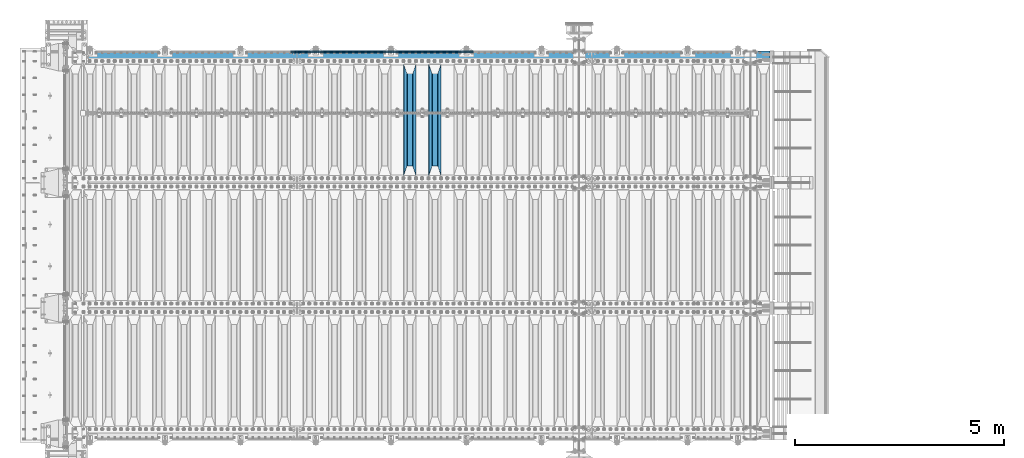
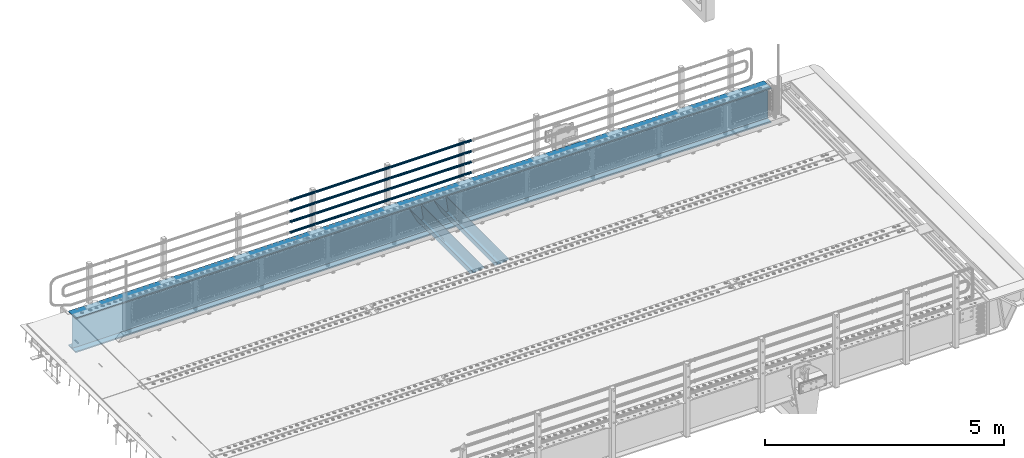
# One storey, part 125 of 247: 7 beams.
"""IFC2X3 building model written with IfcOpenShell, lengths in millimetres."""

from ifc_helpers import new_model, si_unit, frame, origin_with_axes, place, context, subcontext, project, spatial, faceted_brep, material, type_object, element, save


model = new_model("IFC2X3")

# Units and contexts
model_context = context("Model", 3, precision=1e-05, world=origin_with_axes())
body_context = subcontext(model_context, "Body", "Model", "MODEL_VIEW")
ifc_project = project(units=[si_unit("LENGTHUNIT", "METRE", prefix="MILLI"), si_unit("AREAUNIT", "SQUARE_METRE"), si_unit("VOLUMEUNIT", "CUBIC_METRE"), si_unit("MASSUNIT", "GRAM", prefix="KILO"), si_unit("TIMEUNIT", "SECOND"), si_unit("PLANEANGLEUNIT", "RADIAN"), si_unit("SOLIDANGLEUNIT", "STERADIAN"), si_unit("THERMODYNAMICTEMPERATUREUNIT", "DEGREE_CELSIUS"), si_unit("LUMINOUSINTENSITYUNIT", "LUMEN")], contexts=[model_context])

# Site, building, storey
site_placement = place(None, origin_with_axes())
site = spatial("IfcSite", under=ifc_project, at=site_placement, CompositionType="ELEMENT")
building_placement = place(site_placement, origin_with_axes())
building = spatial("IfcBuilding", under=site, at=building_placement, Name="Standard", CompositionType="ELEMENT")
storey_placement = place(building_placement, origin_with_axes())
storey = spatial("IfcBuildingStorey", under=building, at=storey_placement, Name="Undefined", CompositionType="ELEMENT", Elevation=0.0)

# Beams
ifc_material_1 = material(Name="STEEL/S355N")
beam_type_1 = type_object("IfcBeamType", PredefinedType="NOTDEFINED")
beam_1_placement = place(storey_placement, frame((8800.0, 6175.0, -115.0), z_axis=(0.0, 0.0, 1.0), x_axis=(0.0, 1.0, 0.0)))
element("IfcBeam", 1, at=beam_1_placement, inside=storey, type_object=beam_type_1, material=ifc_material_1, context=body_context, shape_type="Brep", body=[
    faceted_brep([(0.0, 150.0, 115.0), (0.0, 143.689999999999, 115.0), (2650.00000000297, 143.689999999999, 115.0), (2650.00000000297, 150.0, 115.0), (2650.00000000297, 142.059565218402, 110.0000000031), (2650.00000000297, 148.369565218403, 110.0000000031), (2441.90079219208, -80.1103600731112, -98.0992078077845), (2437.7588105432, -77.5672621345584, -102.241189456673), (2434.06523489746, -74.4080125315522, -105.934765102404), (2430.91086095089, -70.710272125576, -109.089139048974), (2428.37322971128, -66.5649389910068, -111.626770288588), (2426.51472138054, -62.0739139532889, -113.485278619323), (2425.38102192091, -57.3475956567672, -114.618978078955), (2424.99999999987, -52.5021667386536, -115.0), (2424.99999999987, 52.5021667386536, -115.0), (2425.38102192091, 57.3475956567672, -114.618978078955), (2426.51472138054, 62.0739139532889, -113.485278619323), (2428.37322971128, 66.5649389910068, -111.626770288588), (2430.91086095089, 70.710272125576, -109.089139048974), (2434.06523489746, 74.4080125315522, -105.934765102404), (2437.7588105432, 77.5672621345584, -102.241189456673), (2441.90079219208, 80.1103600731112, -98.0992078077846), (2446.38936140511, 81.9747917625791, -93.6106385947584), (2448.24948500409, 76.2713538057251, -91.7505149957729), (2444.62967112262, 74.76777986261, -95.3703288772456), (2441.28936334126, 72.7168944282894, -98.710636658607), (2438.31067330438, 70.1691124903846, -101.689326695487), (2435.76682334747, 67.1870637758839, -104.233176652398), (2433.72034654133, 63.8440531834895, -106.279653458539), (2432.22154950041, 60.222258798236, -107.778450499454), (2431.30727574265, 56.4107117849089, -108.692724257221), (2430.99999999987, 52.5031078186876, -109.0), (2430.99999999987, -52.5031078186876, -109.0), (2431.30727574265, -56.4107117849089, -108.692724257221), (2432.22154950041, -60.222258798236, -107.778450499454), (2433.72034654133, -63.8440531834895, -106.279653458539), (2435.76682334747, -67.1870637758839, -104.233176652398), (2438.31067330438, -70.1691124903846, -101.689326695487), (2441.28936334126, -72.7168944282894, -98.7106366586071), (2444.62967112262, -74.76777986261, -95.3703288772457), (2448.24948500409, -76.2713538057251, -91.7505149957729), (2650.00000000297, -142.059565218402, 110.0000000031), (2650.00000000297, -148.369565218403, 110.0000000031), (2446.38936140511, -81.9747917625791, -93.6106385947584), (2650.00000000297, -143.689999999999, 115.0), (2650.00000000297, -150.0, 115.0), (0.0, -143.689999999999, 115.0), (0.0, -150.0, 115.0), (0.0, -148.369565218261, 110.000000002663), (203.610638597422, -81.9747917625791, -93.6106385947584), (208.099207810448, -80.1103600731112, -98.0992078077845), (212.241189459336, -77.5672621345584, -102.241189456673), (215.934765105068, -74.4080125315522, -105.934765102404), (219.089139051637, -70.710272125576, -109.089139048974), (221.626770291251, -66.5649389910068, -111.626770288588), (223.485278621985, -62.0739139532889, -113.485278619323), (224.618978081617, -57.3475956567672, -114.618978078955), (225.000000002663, -52.5021667386536, -115.0), (225.000000002663, 52.5021667386536, -115.0), (224.618978081617, 57.3475956567672, -114.618978078955), (223.485278621985, 62.0739139532889, -113.485278619323), (221.626770291251, 66.5649389910068, -111.626770288588), (219.089139051637, 70.710272125576, -109.089139048974), (215.934765105068, 74.4080125315522, -105.934765102404), (212.241189459336, 77.5672621345584, -102.241189456673), (208.099207810448, 80.1103600731112, -98.0992078077846), (203.610638597422, 81.9747917625791, -93.6106385947584), (0.0, 148.369565218261, 110.000000002663), (0.0, 142.05956521826, 110.000000002663), (201.750514998436, 76.2713538057251, -91.7505149957729), (205.370328879908, 74.76777986261, -95.3703288772456), (208.710636661271, 72.7168944282894, -98.710636658607), (211.68932669815, 70.1691124903846, -101.689326695487), (214.233176655061, 67.1870637758839, -104.233176652398), (216.279653461202, 63.8440531834895, -106.279653458539), (217.778450502117, 60.222258798236, -107.778450499454), (218.692724259885, 56.4107117849089, -108.692724257221), (219.000000002663, 52.5031078186876, -109.0), (219.000000002663, -52.5031078186876, -109.0), (218.692724259885, -56.4107117849089, -108.692724257221), (217.778450502117, -60.222258798236, -107.778450499454), (216.279653461202, -63.8440531834895, -106.279653458539), (214.233176655061, -67.1870637758839, -104.233176652398), (211.68932669815, -70.1691124903846, -101.689326695487), (208.710636661271, -72.7168944282894, -98.7106366586071), (205.370328879908, -74.76777986261, -95.3703288772457), (201.750514998436, -76.2713538057251, -91.7505149957729), (0.0, -142.05956521826, 110.000000002663)], [[[0, 1, 2, 3]], [[3, 2, 4, 5]], [[6, 7, 8, 9, 10, 11, 12, 13, 14, 15, 16, 17, 18, 19, 20, 21, 22, 5, 4, 23, 24, 25, 26, 27, 28, 29, 30, 31, 32, 33, 34, 35, 36, 37, 38, 39, 40, 41, 42, 43]], [[44, 45, 42, 41]], [[46, 47, 45, 44]], [[43, 42, 45, 47, 48, 49]], [[6, 43, 49, 50]], [[7, 6, 50, 51]], [[8, 7, 51, 52]], [[9, 8, 52, 53]], [[10, 9, 53, 54]], [[11, 10, 54, 55]], [[12, 11, 55, 56]], [[13, 12, 56, 57]], [[14, 13, 57, 58]], [[15, 14, 58, 59]], [[16, 15, 59, 60]], [[17, 16, 60, 61]], [[18, 17, 61, 62]], [[19, 18, 62, 63]], [[20, 19, 63, 64]], [[21, 20, 64, 65]], [[22, 21, 65, 66]], [[0, 3, 5, 22, 66, 67]], [[1, 0, 67, 68]], [[23, 4, 2, 1, 68, 69]], [[24, 23, 69, 70]], [[25, 24, 70, 71]], [[26, 25, 71, 72]], [[27, 26, 72, 73]], [[28, 27, 73, 74]], [[29, 28, 74, 75]], [[30, 29, 75, 76]], [[31, 30, 76, 77]], [[32, 31, 77, 78]], [[33, 32, 78, 79]], [[34, 33, 79, 80]], [[35, 34, 80, 81]], [[36, 35, 81, 82]], [[37, 36, 82, 83]], [[38, 37, 83, 84]], [[39, 38, 84, 85]], [[40, 39, 85, 86]], [[46, 44, 41, 40, 86, 87]], [[47, 46, 87, 48]], [[86, 85, 84, 83, 82, 81, 80, 79, 78, 77, 76, 75, 74, 73, 72, 71, 70, 69, 68, 67, 66, 65, 64, 63, 62, 61, 60, 59, 58, 57, 56, 55, 54, 53, 52, 51, 50, 49, 48, 87]]]),
])
beam_2_placement = place(storey_placement, frame((8200.0, 6175.0, -115.0), z_axis=(0.0, 0.0, 1.0), x_axis=(0.0, 1.0, 0.0)))
element("IfcBeam", 2, at=beam_2_placement, inside=storey, type_object=beam_type_1, material=ifc_material_1, context=body_context, shape_type="Brep", body=[
    faceted_brep([(0.0, 150.0, 115.0), (0.0, 143.689999999999, 115.0), (2650.00000000297, 143.689999999999, 115.0), (2650.00000000297, 150.0, 115.0), (2650.00000000297, 142.059565218402, 110.0000000031), (2650.00000000297, 148.369565218403, 110.0000000031), (2441.90079219208, -80.1103600731112, -98.0992078077845), (2437.7588105432, -77.5672621345584, -102.241189456673), (2434.06523489746, -74.4080125315522, -105.934765102404), (2430.91086095089, -70.710272125576, -109.089139048974), (2428.37322971128, -66.5649389910068, -111.626770288588), (2426.51472138054, -62.0739139532889, -113.485278619323), (2425.38102192091, -57.3475956567672, -114.618978078955), (2424.99999999987, -52.5021667386536, -115.0), (2424.99999999987, 52.5021667386536, -115.0), (2425.38102192091, 57.3475956567672, -114.618978078955), (2426.51472138054, 62.0739139532889, -113.485278619323), (2428.37322971128, 66.5649389910068, -111.626770288588), (2430.91086095089, 70.710272125576, -109.089139048974), (2434.06523489746, 74.4080125315522, -105.934765102404), (2437.7588105432, 77.5672621345584, -102.241189456673), (2441.90079219208, 80.1103600731112, -98.0992078077846), (2446.38936140511, 81.9747917625791, -93.6106385947584), (2448.24948500409, 76.2713538057251, -91.7505149957729), (2444.62967112262, 74.76777986261, -95.3703288772456), (2441.28936334126, 72.7168944282894, -98.710636658607), (2438.31067330438, 70.1691124903846, -101.689326695487), (2435.76682334747, 67.1870637758839, -104.233176652398), (2433.72034654133, 63.8440531834895, -106.279653458539), (2432.22154950041, 60.222258798236, -107.778450499454), (2431.30727574265, 56.4107117849089, -108.692724257221), (2430.99999999987, 52.5031078186876, -109.0), (2430.99999999987, -52.5031078186876, -109.0), (2431.30727574265, -56.4107117849089, -108.692724257221), (2432.22154950041, -60.222258798236, -107.778450499454), (2433.72034654133, -63.8440531834895, -106.279653458539), (2435.76682334747, -67.1870637758839, -104.233176652398), (2438.31067330438, -70.1691124903846, -101.689326695487), (2441.28936334126, -72.7168944282894, -98.7106366586071), (2444.62967112262, -74.76777986261, -95.3703288772457), (2448.24948500409, -76.2713538057251, -91.7505149957729), (2650.00000000297, -142.059565218402, 110.0000000031), (2650.00000000297, -148.369565218403, 110.0000000031), (2446.38936140511, -81.9747917625791, -93.6106385947584), (2650.00000000297, -143.689999999999, 115.0), (2650.00000000297, -150.0, 115.0), (0.0, -143.689999999999, 115.0), (0.0, -150.0, 115.0), (0.0, -148.369565218261, 110.000000002663), (203.610638597422, -81.9747917625791, -93.6106385947584), (208.099207810448, -80.1103600731112, -98.0992078077845), (212.241189459336, -77.5672621345584, -102.241189456673), (215.934765105068, -74.4080125315522, -105.934765102404), (219.089139051637, -70.710272125576, -109.089139048974), (221.626770291251, -66.5649389910068, -111.626770288588), (223.485278621985, -62.0739139532889, -113.485278619323), (224.618978081617, -57.3475956567672, -114.618978078955), (225.000000002663, -52.5021667386536, -115.0), (225.000000002663, 52.5021667386536, -115.0), (224.618978081617, 57.3475956567672, -114.618978078955), (223.485278621985, 62.0739139532889, -113.485278619323), (221.626770291251, 66.5649389910068, -111.626770288588), (219.089139051637, 70.710272125576, -109.089139048974), (215.934765105068, 74.4080125315522, -105.934765102404), (212.241189459336, 77.5672621345584, -102.241189456673), (208.099207810448, 80.1103600731112, -98.0992078077846), (203.610638597422, 81.9747917625791, -93.6106385947584), (0.0, 148.369565218261, 110.000000002663), (0.0, 142.05956521826, 110.000000002663), (201.750514998436, 76.2713538057251, -91.7505149957729), (205.370328879908, 74.76777986261, -95.3703288772456), (208.710636661271, 72.7168944282894, -98.710636658607), (211.68932669815, 70.1691124903846, -101.689326695487), (214.233176655061, 67.1870637758839, -104.233176652398), (216.279653461202, 63.8440531834895, -106.279653458539), (217.778450502117, 60.222258798236, -107.778450499454), (218.692724259885, 56.4107117849089, -108.692724257221), (219.000000002663, 52.5031078186876, -109.0), (219.000000002663, -52.5031078186876, -109.0), (218.692724259885, -56.4107117849089, -108.692724257221), (217.778450502117, -60.222258798236, -107.778450499454), (216.279653461202, -63.8440531834895, -106.279653458539), (214.233176655061, -67.1870637758839, -104.233176652398), (211.68932669815, -70.1691124903846, -101.689326695487), (208.710636661271, -72.7168944282894, -98.7106366586071), (205.370328879908, -74.76777986261, -95.3703288772457), (201.750514998436, -76.2713538057251, -91.7505149957729), (0.0, -142.05956521826, 110.000000002663)], [[[0, 1, 2, 3]], [[3, 2, 4, 5]], [[6, 7, 8, 9, 10, 11, 12, 13, 14, 15, 16, 17, 18, 19, 20, 21, 22, 5, 4, 23, 24, 25, 26, 27, 28, 29, 30, 31, 32, 33, 34, 35, 36, 37, 38, 39, 40, 41, 42, 43]], [[44, 45, 42, 41]], [[46, 47, 45, 44]], [[43, 42, 45, 47, 48, 49]], [[6, 43, 49, 50]], [[7, 6, 50, 51]], [[8, 7, 51, 52]], [[9, 8, 52, 53]], [[10, 9, 53, 54]], [[11, 10, 54, 55]], [[12, 11, 55, 56]], [[13, 12, 56, 57]], [[14, 13, 57, 58]], [[15, 14, 58, 59]], [[16, 15, 59, 60]], [[17, 16, 60, 61]], [[18, 17, 61, 62]], [[19, 18, 62, 63]], [[20, 19, 63, 64]], [[21, 20, 64, 65]], [[22, 21, 65, 66]], [[0, 3, 5, 22, 66, 67]], [[1, 0, 67, 68]], [[23, 4, 2, 1, 68, 69]], [[24, 23, 69, 70]], [[25, 24, 70, 71]], [[26, 25, 71, 72]], [[27, 26, 72, 73]], [[28, 27, 73, 74]], [[29, 28, 74, 75]], [[30, 29, 75, 76]], [[31, 30, 76, 77]], [[32, 31, 77, 78]], [[33, 32, 78, 79]], [[34, 33, 79, 80]], [[35, 34, 80, 81]], [[36, 35, 81, 82]], [[37, 36, 82, 83]], [[38, 37, 83, 84]], [[39, 38, 84, 85]], [[40, 39, 85, 86]], [[46, 44, 41, 40, 86, 87]], [[47, 46, 87, 48]], [[86, 85, 84, 83, 82, 81, 80, 79, 78, 77, 76, 75, 74, 73, 72, 71, 70, 69, 68, 67, 66, 65, 64, 63, 62, 61, 60, 59, 58, 57, 56, 55, 54, 53, 52, 51, 50, 49, 48, 87]]]),
])
ifc_material_2 = material()
beam_type_2 = type_object("IfcBeamType", PredefinedType="NOTDEFINED")
beam_3_placement = place(storey_placement, frame((9727.99999999987, 9129.85000000009, 149.849999999725), z_axis=(0.0, 0.0, -1.0), x_axis=(-1.0, 0.0, 0.0)))
element("IfcBeam", 3, at=beam_3_placement, inside=storey, type_object=beam_type_2, material=ifc_material_2, context=body_context, shape_type="Brep", body=[
    faceted_brep([(0.0, -26.5499999999993, 0.0), (0.0, -24.5290015881747, 10.1602451292931), (4384.00249699992, -24.5290015881747, 10.1602451292931), (4384.00249699992, -26.5499999999993, 0.0), (0.0, -18.7736850405036, 18.7736850405028), (4384.00249699992, -18.7736850405036, 18.7736850405028), (0.0, -10.1602451292929, 24.5290015881747), (4384.00249699992, -10.1602451292929, 24.5290015881747), (0.0, 0.0, 26.55), (4384.00249699992, 0.0, 26.55), (0.0, 10.1602451292929, 24.5290015881747), (4384.00249699992, 10.1602451292929, 24.5290015881747), (0.0, 18.7736850405036, 18.7736850405028), (4384.00249699992, 18.7736850405036, 18.7736850405028), (0.0, 24.5290015881747, 10.1602451292931), (4384.00249699992, 24.5290015881747, 10.1602451292931), (0.0, 26.5499999999993, 0.0), (4384.00249699992, 26.5499999999993, 0.0), (0.0, 24.5290015881747, -10.1602451292931), (4384.00249699992, 24.5290015881747, -10.1602451292931), (0.0, 18.7736850405036, -18.7736850405028), (4384.00249699992, 18.7736850405036, -18.7736850405028), (0.0, 10.1602451292929, -24.5290015881747), (4384.00249699992, 10.1602451292929, -24.5290015881747), (0.0, 0.0, -26.55), (4384.00249699992, 0.0, -26.55), (0.0, -10.1602451292929, -24.5290015881747), (4384.00249699992, -10.1602451292929, -24.5290015881747), (0.0, -18.7736850405036, -18.7736850405028), (4384.00249699992, -18.7736850405036, -18.7736850405028), (0.0, -24.5290015881747, -10.1602451292931), (4384.00249699992, -24.5290015881747, -10.1602451292931), (0.0, -30.1499999999996, 0.0), (0.0, -27.8549679052148, -11.5379054858076), (4384.00249699992, -27.8549679052157, -11.5379054858075), (4384.00249699992, -30.1499999999996, 0.0), (0.0, -21.3192694527743, -21.3192694527752), (4384.00249699992, -21.3192694527752, -21.3192694527744), (0.0, -11.5379054858076, -27.8549679052157), (4384.00249699992, -11.5379054858076, -27.8549679052153), (0.0, 0.0, -30.1499999999996), (4384.00249699992, 0.0, -30.15), (0.0, 11.5379054858076, -27.8549679052157), (4384.00249699992, 11.5379054858076, -27.8549679052153), (0.0, 21.3192694527743, -21.3192694527752), (4384.00249699992, 21.3192694527752, -21.3192694527744), (0.0, 27.8549679052157, -11.5379054858076), (4384.00249699992, 27.8549679052157, -11.5379054858074), (0.0, 30.1499999999996, 0.0), (4384.00249699992, 30.1499999999996, 0.0), (0.0, 27.8549679052157, 11.5379054858076), (4384.00249699992, 27.8549679052157, 11.5379054858075), (0.0, 21.3192694527743, 21.3192694527752), (4384.00249699992, 21.3192694527752, 21.3192694527744), (0.0, 11.5379054858076, 27.8549679052157), (4384.00249699992, 11.5379054858076, 27.8549679052153), (0.0, 0.0, 30.1499999999996), (4384.00249699992, 0.0, 30.15), (0.0, -11.5379054858076, 27.8549679052157), (4384.00249699992, -11.5379054858076, 27.8549679052153), (0.0, -21.3192694527743, 21.3192694527752), (4384.00249699992, -21.3192694527752, 21.3192694527744), (0.0, -27.8549679052157, 11.5379054858076), (4384.00249699992, -27.8549679052157, 11.5379054858075)], [[[0, 1, 2, 3]], [[1, 4, 5, 2]], [[4, 6, 7, 5]], [[6, 8, 9, 7]], [[8, 10, 11, 9]], [[10, 12, 13, 11]], [[12, 14, 15, 13]], [[14, 16, 17, 15]], [[16, 18, 19, 17]], [[18, 20, 21, 19]], [[20, 22, 23, 21]], [[22, 24, 25, 23]], [[24, 26, 27, 25]], [[26, 28, 29, 27]], [[28, 30, 31, 29]], [[30, 0, 3, 31]], [[32, 33, 34, 35]], [[33, 36, 37, 34]], [[36, 38, 39, 37]], [[38, 40, 41, 39]], [[40, 42, 43, 41]], [[42, 44, 45, 43]], [[44, 46, 47, 45]], [[46, 48, 49, 47]], [[48, 50, 51, 49]], [[50, 52, 53, 51]], [[52, 54, 55, 53]], [[54, 56, 57, 55]], [[56, 58, 59, 57]], [[58, 60, 61, 59]], [[60, 62, 63, 61]], [[62, 32, 35, 63]], [[37, 39, 41, 43, 45, 47, 49, 51, 53, 55, 57, 59, 61, 63, 35, 34], [5, 7, 9, 11, 13, 15, 17, 19, 21, 23, 25, 27, 29, 31, 3, 2]], [[62, 60, 58, 56, 54, 52, 50, 48, 46, 44, 42, 40, 38, 36, 33, 32], [30, 28, 26, 24, 22, 20, 18, 16, 14, 12, 10, 8, 6, 4, 1, 0]]]),
])
beam_4_placement = place(storey_placement, frame((9727.99999999987, 9129.85000000009, 420.149999999728), z_axis=(0.0, 0.0, -1.0), x_axis=(-1.0, 0.0, 0.0)))
element("IfcBeam", 4, at=beam_4_placement, inside=storey, type_object=beam_type_2, material=ifc_material_2, context=body_context, shape_type="Brep", body=[
    faceted_brep([(0.0, -26.5499999999993, 0.0), (0.0, -24.5290015881747, 10.1602451292931), (4384.00249699992, -24.5290015881747, 10.1602451292931), (4384.00249699992, -26.5499999999993, 0.0), (0.0, -18.7736850405036, 18.7736850405028), (4384.00249699992, -18.7736850405036, 18.7736850405028), (0.0, -10.1602451292929, 24.5290015881747), (4384.00249699992, -10.1602451292929, 24.5290015881747), (0.0, 0.0, 26.55), (4384.00249699992, 0.0, 26.55), (0.0, 10.1602451292929, 24.5290015881747), (4384.00249699992, 10.1602451292929, 24.5290015881747), (0.0, 18.7736850405036, 18.7736850405028), (4384.00249699992, 18.7736850405036, 18.7736850405028), (0.0, 24.5290015881747, 10.1602451292931), (4384.00249699992, 24.5290015881747, 10.1602451292931), (0.0, 26.5499999999993, 0.0), (4384.00249699992, 26.5499999999993, 0.0), (0.0, 24.5290015881747, -10.1602451292931), (4384.00249699992, 24.5290015881747, -10.1602451292931), (0.0, 18.7736850405036, -18.7736850405028), (4384.00249699992, 18.7736850405036, -18.7736850405028), (0.0, 10.1602451292929, -24.5290015881747), (4384.00249699992, 10.1602451292929, -24.5290015881747), (0.0, 0.0, -26.55), (4384.00249699992, 0.0, -26.55), (0.0, -10.1602451292929, -24.5290015881747), (4384.00249699992, -10.1602451292929, -24.5290015881747), (0.0, -18.7736850405036, -18.7736850405028), (4384.00249699992, -18.7736850405036, -18.7736850405028), (0.0, -24.5290015881747, -10.1602451292931), (4384.00249699992, -24.5290015881747, -10.1602451292931), (0.0, -30.1499999999996, 0.0), (0.0, -27.8549679052148, -11.5379054858076), (4384.00249699992, -27.8549679052157, -11.5379054858075), (4384.00249699992, -30.1499999999996, 0.0), (0.0, -21.3192694527743, -21.3192694527752), (4384.00249699992, -21.3192694527752, -21.3192694527744), (0.0, -11.5379054858076, -27.8549679052157), (4384.00249699992, -11.5379054858076, -27.8549679052153), (0.0, 0.0, -30.1499999999996), (4384.00249699992, 0.0, -30.15), (0.0, 11.5379054858076, -27.8549679052157), (4384.00249699992, 11.5379054858076, -27.8549679052153), (0.0, 21.3192694527743, -21.3192694527752), (4384.00249699992, 21.3192694527752, -21.3192694527744), (0.0, 27.8549679052157, -11.5379054858076), (4384.00249699992, 27.8549679052157, -11.5379054858074), (0.0, 30.1499999999996, 0.0), (4384.00249699992, 30.1499999999996, 0.0), (0.0, 27.8549679052157, 11.5379054858076), (4384.00249699992, 27.8549679052157, 11.5379054858075), (0.0, 21.3192694527743, 21.3192694527752), (4384.00249699992, 21.3192694527752, 21.3192694527744), (0.0, 11.5379054858076, 27.8549679052157), (4384.00249699992, 11.5379054858076, 27.8549679052153), (0.0, 0.0, 30.1499999999996), (4384.00249699992, 0.0, 30.15), (0.0, -11.5379054858076, 27.8549679052157), (4384.00249699992, -11.5379054858076, 27.8549679052153), (0.0, -21.3192694527743, 21.3192694527752), (4384.00249699992, -21.3192694527752, 21.3192694527744), (0.0, -27.8549679052157, 11.5379054858076), (4384.00249699992, -27.8549679052157, 11.5379054858075)], [[[0, 1, 2, 3]], [[1, 4, 5, 2]], [[4, 6, 7, 5]], [[6, 8, 9, 7]], [[8, 10, 11, 9]], [[10, 12, 13, 11]], [[12, 14, 15, 13]], [[14, 16, 17, 15]], [[16, 18, 19, 17]], [[18, 20, 21, 19]], [[20, 22, 23, 21]], [[22, 24, 25, 23]], [[24, 26, 27, 25]], [[26, 28, 29, 27]], [[28, 30, 31, 29]], [[30, 0, 3, 31]], [[32, 33, 34, 35]], [[33, 36, 37, 34]], [[36, 38, 39, 37]], [[38, 40, 41, 39]], [[40, 42, 43, 41]], [[42, 44, 45, 43]], [[44, 46, 47, 45]], [[46, 48, 49, 47]], [[48, 50, 51, 49]], [[50, 52, 53, 51]], [[52, 54, 55, 53]], [[54, 56, 57, 55]], [[56, 58, 59, 57]], [[58, 60, 61, 59]], [[60, 62, 63, 61]], [[62, 32, 35, 63]], [[37, 39, 41, 43, 45, 47, 49, 51, 53, 55, 57, 59, 61, 63, 35, 34], [5, 7, 9, 11, 13, 15, 17, 19, 21, 23, 25, 27, 29, 31, 3, 2]], [[62, 60, 58, 56, 54, 52, 50, 48, 46, 44, 42, 40, 38, 36, 33, 32], [30, 28, 26, 24, 22, 20, 18, 16, 14, 12, 10, 8, 6, 4, 1, 0]]]),
])
beam_5_placement = place(storey_placement, frame((9727.99999999987, 9129.85000000009, 969.849999999725), z_axis=(0.0, 0.0, -1.0), x_axis=(-1.0, 0.0, 0.0)))
element("IfcBeam", 5, at=beam_5_placement, inside=storey, type_object=beam_type_2, material=ifc_material_2, context=body_context, shape_type="Brep", body=[
    faceted_brep([(0.0, -26.5499999999993, 0.0), (0.0, -24.5290015881747, 10.1602451292931), (4384.00249699992, -24.5290015881747, 10.1602451292931), (4384.00249699992, -26.5499999999993, 0.0), (0.0, -18.7736850405036, 18.7736850405028), (4384.00249699992, -18.7736850405036, 18.7736850405028), (0.0, -10.1602451292929, 24.5290015881747), (4384.00249699992, -10.1602451292929, 24.5290015881747), (0.0, 0.0, 26.55), (4384.00249699992, 0.0, 26.55), (0.0, 10.1602451292929, 24.5290015881747), (4384.00249699992, 10.1602451292929, 24.5290015881747), (0.0, 18.7736850405036, 18.7736850405028), (4384.00249699992, 18.7736850405036, 18.7736850405028), (0.0, 24.5290015881747, 10.1602451292931), (4384.00249699992, 24.5290015881747, 10.1602451292931), (0.0, 26.5499999999993, 0.0), (4384.00249699992, 26.5499999999993, 0.0), (0.0, 24.5290015881747, -10.1602451292931), (4384.00249699992, 24.5290015881747, -10.1602451292931), (0.0, 18.7736850405036, -18.7736850405028), (4384.00249699992, 18.7736850405036, -18.7736850405028), (0.0, 10.1602451292929, -24.5290015881747), (4384.00249699992, 10.1602451292929, -24.5290015881747), (0.0, 0.0, -26.55), (4384.00249699992, 0.0, -26.55), (0.0, -10.1602451292929, -24.5290015881747), (4384.00249699992, -10.1602451292929, -24.5290015881747), (0.0, -18.7736850405036, -18.7736850405028), (4384.00249699992, -18.7736850405036, -18.7736850405028), (0.0, -24.5290015881747, -10.1602451292931), (4384.00249699992, -24.5290015881747, -10.1602451292931), (0.0, -30.1499999999996, 0.0), (0.0, -27.8549679052148, -11.5379054858076), (4384.00249699992, -27.8549679052157, -11.5379054858075), (4384.00249699992, -30.1499999999996, 0.0), (0.0, -21.3192694527743, -21.3192694527752), (4384.00249699992, -21.3192694527752, -21.3192694527744), (0.0, -11.5379054858076, -27.8549679052157), (4384.00249699992, -11.5379054858076, -27.8549679052153), (0.0, 0.0, -30.1499999999996), (4384.00249699992, 0.0, -30.15), (0.0, 11.5379054858076, -27.8549679052157), (4384.00249699992, 11.5379054858076, -27.8549679052153), (0.0, 21.3192694527743, -21.3192694527752), (4384.00249699992, 21.3192694527752, -21.3192694527744), (0.0, 27.8549679052157, -11.5379054858076), (4384.00249699992, 27.8549679052157, -11.5379054858074), (0.0, 30.1499999999996, 0.0), (4384.00249699992, 30.1499999999996, 0.0), (0.0, 27.8549679052157, 11.5379054858076), (4384.00249699992, 27.8549679052157, 11.5379054858075), (0.0, 21.3192694527743, 21.3192694527752), (4384.00249699992, 21.3192694527752, 21.3192694527744), (0.0, 11.5379054858076, 27.8549679052157), (4384.00249699992, 11.5379054858076, 27.8549679052153), (0.0, 0.0, 30.1499999999996), (4384.00249699992, 0.0, 30.15), (0.0, -11.5379054858076, 27.8549679052157), (4384.00249699992, -11.5379054858076, 27.8549679052153), (0.0, -21.3192694527743, 21.3192694527752), (4384.00249699992, -21.3192694527752, 21.3192694527744), (0.0, -27.8549679052157, 11.5379054858076), (4384.00249699992, -27.8549679052157, 11.5379054858075)], [[[0, 1, 2, 3]], [[1, 4, 5, 2]], [[4, 6, 7, 5]], [[6, 8, 9, 7]], [[8, 10, 11, 9]], [[10, 12, 13, 11]], [[12, 14, 15, 13]], [[14, 16, 17, 15]], [[16, 18, 19, 17]], [[18, 20, 21, 19]], [[20, 22, 23, 21]], [[22, 24, 25, 23]], [[24, 26, 27, 25]], [[26, 28, 29, 27]], [[28, 30, 31, 29]], [[30, 0, 3, 31]], [[32, 33, 34, 35]], [[33, 36, 37, 34]], [[36, 38, 39, 37]], [[38, 40, 41, 39]], [[40, 42, 43, 41]], [[42, 44, 45, 43]], [[44, 46, 47, 45]], [[46, 48, 49, 47]], [[48, 50, 51, 49]], [[50, 52, 53, 51]], [[52, 54, 55, 53]], [[54, 56, 57, 55]], [[56, 58, 59, 57]], [[58, 60, 61, 59]], [[60, 62, 63, 61]], [[62, 32, 35, 63]], [[37, 39, 41, 43, 45, 47, 49, 51, 53, 55, 57, 59, 61, 63, 35, 34], [5, 7, 9, 11, 13, 15, 17, 19, 21, 23, 25, 27, 29, 31, 3, 2]], [[62, 60, 58, 56, 54, 52, 50, 48, 46, 44, 42, 40, 38, 36, 33, 32], [30, 28, 26, 24, 22, 20, 18, 16, 14, 12, 10, 8, 6, 4, 1, 0]]]),
])
beam_6_placement = place(storey_placement, frame((9727.99999999987, 9129.85000000009, 689.849999999725), z_axis=(0.0, 0.0, -1.0), x_axis=(-1.0, 0.0, 0.0)))
element("IfcBeam", 6, at=beam_6_placement, inside=storey, type_object=beam_type_2, material=ifc_material_2, context=body_context, shape_type="Brep", body=[
    faceted_brep([(0.0, -26.5499999999993, 0.0), (0.0, -24.5290015881747, 10.1602451292931), (4384.00249699992, -24.5290015881747, 10.1602451292931), (4384.00249699992, -26.5499999999993, 0.0), (0.0, -18.7736850405036, 18.7736850405028), (4384.00249699992, -18.7736850405036, 18.7736850405028), (0.0, -10.1602451292929, 24.5290015881747), (4384.00249699992, -10.1602451292929, 24.5290015881747), (0.0, 0.0, 26.55), (4384.00249699992, 0.0, 26.55), (0.0, 10.1602451292929, 24.5290015881747), (4384.00249699992, 10.1602451292929, 24.5290015881747), (0.0, 18.7736850405036, 18.7736850405028), (4384.00249699992, 18.7736850405036, 18.7736850405028), (0.0, 24.5290015881747, 10.1602451292931), (4384.00249699992, 24.5290015881747, 10.1602451292931), (0.0, 26.5499999999993, 0.0), (4384.00249699992, 26.5499999999993, 0.0), (0.0, 24.5290015881747, -10.1602451292931), (4384.00249699992, 24.5290015881747, -10.1602451292931), (0.0, 18.7736850405036, -18.7736850405028), (4384.00249699992, 18.7736850405036, -18.7736850405028), (0.0, 10.1602451292929, -24.5290015881747), (4384.00249699992, 10.1602451292929, -24.5290015881747), (0.0, 0.0, -26.55), (4384.00249699992, 0.0, -26.55), (0.0, -10.1602451292929, -24.5290015881747), (4384.00249699992, -10.1602451292929, -24.5290015881747), (0.0, -18.7736850405036, -18.7736850405028), (4384.00249699992, -18.7736850405036, -18.7736850405028), (0.0, -24.5290015881747, -10.1602451292931), (4384.00249699992, -24.5290015881747, -10.1602451292931), (0.0, -30.1499999999996, 0.0), (0.0, -27.8549679052148, -11.5379054858076), (4384.00249699992, -27.8549679052157, -11.5379054858075), (4384.00249699992, -30.1499999999996, 0.0), (0.0, -21.3192694527743, -21.3192694527752), (4384.00249699992, -21.3192694527752, -21.3192694527744), (0.0, -11.5379054858076, -27.8549679052157), (4384.00249699992, -11.5379054858076, -27.8549679052153), (0.0, 0.0, -30.1499999999996), (4384.00249699992, 0.0, -30.15), (0.0, 11.5379054858076, -27.8549679052157), (4384.00249699992, 11.5379054858076, -27.8549679052153), (0.0, 21.3192694527743, -21.3192694527752), (4384.00249699992, 21.3192694527752, -21.3192694527744), (0.0, 27.8549679052157, -11.5379054858076), (4384.00249699992, 27.8549679052157, -11.5379054858074), (0.0, 30.1499999999996, 0.0), (4384.00249699992, 30.1499999999996, 0.0), (0.0, 27.8549679052157, 11.5379054858076), (4384.00249699992, 27.8549679052157, 11.5379054858075), (0.0, 21.3192694527743, 21.3192694527752), (4384.00249699992, 21.3192694527752, 21.3192694527744), (0.0, 11.5379054858076, 27.8549679052157), (4384.00249699992, 11.5379054858076, 27.8549679052153), (0.0, 0.0, 30.1499999999996), (4384.00249699992, 0.0, 30.15), (0.0, -11.5379054858076, 27.8549679052157), (4384.00249699992, -11.5379054858076, 27.8549679052153), (0.0, -21.3192694527743, 21.3192694527752), (4384.00249699992, -21.3192694527752, 21.3192694527744), (0.0, -27.8549679052157, 11.5379054858076), (4384.00249699992, -27.8549679052157, 11.5379054858075)], [[[0, 1, 2, 3]], [[1, 4, 5, 2]], [[4, 6, 7, 5]], [[6, 8, 9, 7]], [[8, 10, 11, 9]], [[10, 12, 13, 11]], [[12, 14, 15, 13]], [[14, 16, 17, 15]], [[16, 18, 19, 17]], [[18, 20, 21, 19]], [[20, 22, 23, 21]], [[22, 24, 25, 23]], [[24, 26, 27, 25]], [[26, 28, 29, 27]], [[28, 30, 31, 29]], [[30, 0, 3, 31]], [[32, 33, 34, 35]], [[33, 36, 37, 34]], [[36, 38, 39, 37]], [[38, 40, 41, 39]], [[40, 42, 43, 41]], [[42, 44, 45, 43]], [[44, 46, 47, 45]], [[46, 48, 49, 47]], [[48, 50, 51, 49]], [[50, 52, 53, 51]], [[52, 54, 55, 53]], [[54, 56, 57, 55]], [[56, 58, 59, 57]], [[58, 60, 61, 59]], [[60, 62, 63, 61]], [[62, 32, 35, 63]], [[37, 39, 41, 43, 45, 47, 49, 51, 53, 55, 57, 59, 61, 63, 35, 34], [5, 7, 9, 11, 13, 15, 17, 19, 21, 23, 25, 27, 29, 31, 3, 2]], [[62, 60, 58, 56, 54, 52, 50, 48, 46, 44, 42, 40, 38, 36, 33, 32], [30, 28, 26, 24, 22, 20, 18, 16, 14, 12, 10, 8, 6, 4, 1, 0]]]),
])
beam_type_3 = type_object("IfcBeamType", Name="HEA900", PredefinedType="NOTDEFINED")
beam_7_placement = place(storey_placement, frame((10.0, 9000.0, -445.0), z_axis=(0.0, 0.0, 1.0), x_axis=(1.0, 0.0, 0.0)))
element("IfcBeam", 7, at=beam_7_placement, inside=storey, type_object=beam_type_3, material=ifc_material_1, ObjectType="HEA900", context=body_context, shape_type="Brep", body=[
    faceted_brep([(0.0, 150.0, -445.0), (0.0, 150.0, -415.0), (16807.0, 150.0, -415.0), (16807.0, 150.0, -445.0), (0.0, 8.0, -415.0), (16807.0, 8.0, -415.0), (0.0, 8.0, 415.0), (16807.0, 8.0, 415.0), (0.0, 150.0, 415.0), (16807.0, 150.0, 415.0), (0.0, 150.0, 445.0), (16807.0, 150.0, 445.0), (0.0, -150.0, 445.0), (16807.0, -150.0, 445.0), (0.0, -150.0, 415.0), (16807.0, -150.0, 415.0), (0.0, -8.0, 415.0), (16807.0, -8.0, 415.0), (0.0, -8.0, -415.0), (16807.0, -8.0, -415.0), (0.0, -150.0, -415.0), (16807.0, -150.0, -415.0), (0.0, -150.0, -445.0), (16807.0, -150.0, -445.0)], [[[0, 1, 2, 3]], [[1, 4, 5, 2]], [[4, 6, 7, 5]], [[6, 8, 9, 7]], [[8, 10, 11, 9]], [[10, 12, 13, 11]], [[12, 14, 15, 13]], [[14, 16, 17, 15]], [[16, 18, 19, 17]], [[18, 20, 21, 19]], [[20, 22, 23, 21]], [[22, 0, 3, 23]], [[5, 7, 9, 11, 13, 15, 17, 19, 21, 23, 3, 2]], [[22, 20, 18, 16, 14, 12, 10, 8, 6, 4, 1, 0]]]),
])

save(model, "model.ifc")
